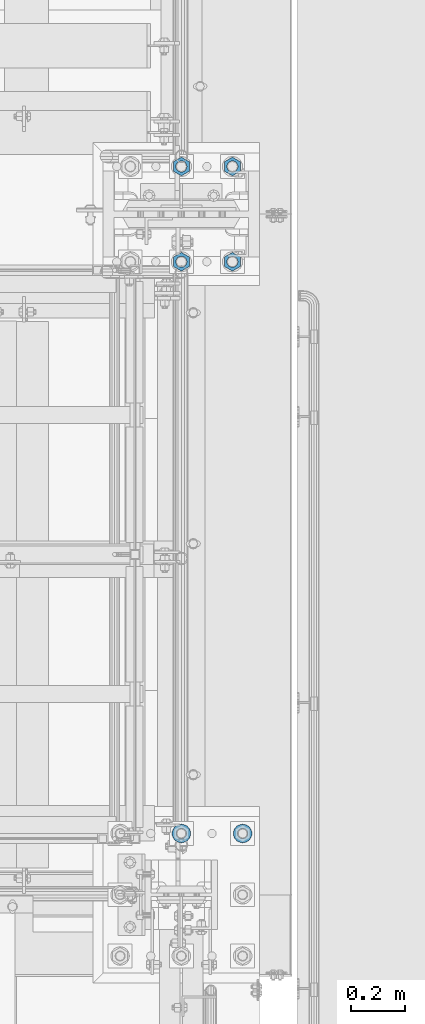
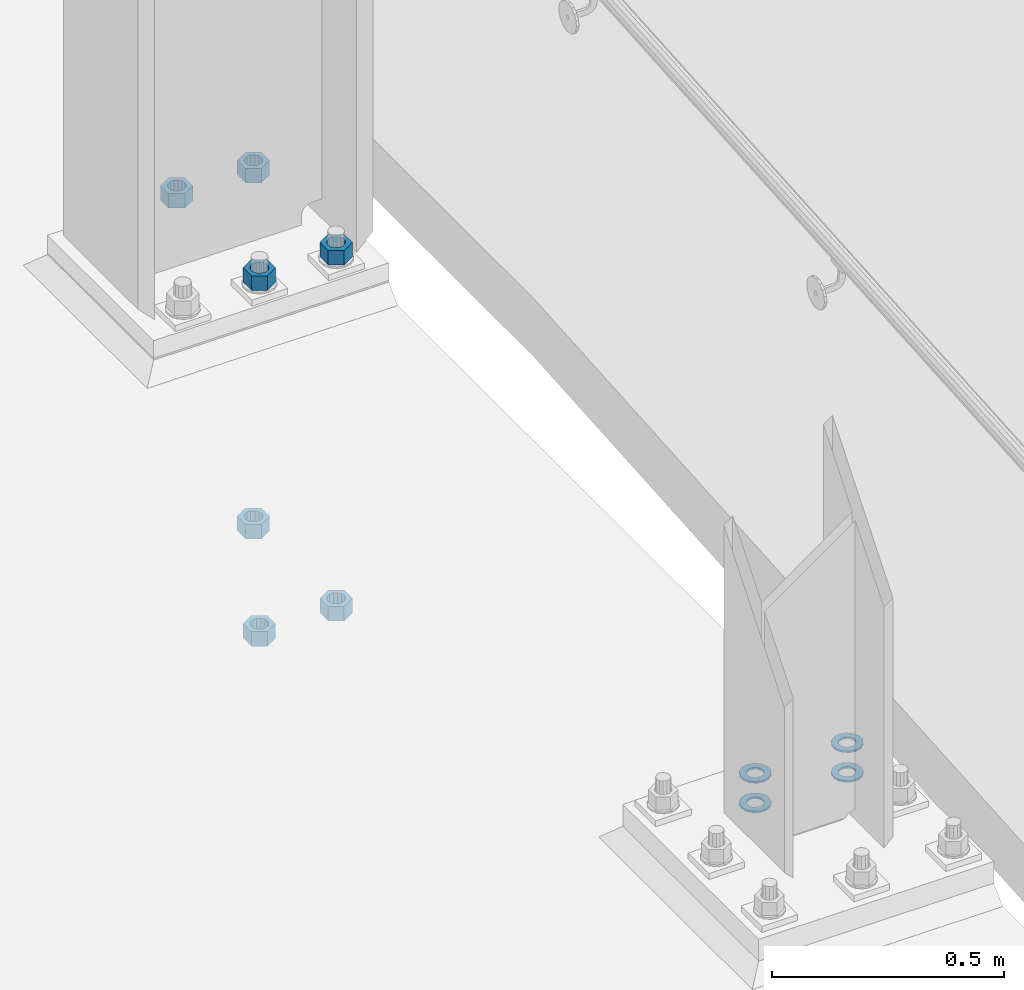
# One storey, part 902 of 1876: 11 columns, 2 elements without a shape of their own.
"""IFC2X3 building model written with IfcOpenShell, lengths in millimetres."""

from ifc_helpers import new_model, si_unit, frame, origin_with_axes, place, context, subcontext, project, spatial, faceted_brep, material, type_object, element, aggregate, save


model = new_model("IFC2X3")

# Units and contexts
model_context = context("Model", 3, precision=1e-05, world=origin_with_axes())
body_context = subcontext(model_context, "Body", "Model", "MODEL_VIEW")
ifc_project = project(units=[si_unit("LENGTHUNIT", "METRE", prefix="MILLI"), si_unit("AREAUNIT", "SQUARE_METRE"), si_unit("VOLUMEUNIT", "CUBIC_METRE"), si_unit("MASSUNIT", "GRAM", prefix="KILO"), si_unit("TIMEUNIT", "SECOND"), si_unit("PLANEANGLEUNIT", "RADIAN"), si_unit("SOLIDANGLEUNIT", "STERADIAN"), si_unit("THERMODYNAMICTEMPERATUREUNIT", "DEGREE_CELSIUS"), si_unit("LUMINOUSINTENSITYUNIT", "LUMEN")], contexts=[model_context])

# Site, building, storey
site_placement = place(None, origin_with_axes())
site = spatial("IfcSite", under=ifc_project, at=site_placement, CompositionType="ELEMENT")
building_placement = place(site_placement, origin_with_axes())
building = spatial("IfcBuilding", under=site, at=building_placement, Name="Undefined", CompositionType="ELEMENT")
storey_placement = place(building_placement, origin_with_axes())
storey = spatial("IfcBuildingStorey", under=building, at=storey_placement, Name="Undefined", CompositionType="ELEMENT", Elevation=0.0)

# Assembly, columns
assembly_1_placement = place(storey_placement, origin_with_axes())
assembly_1 = element("IfcElementAssembly", 1, at=assembly_1_placement, inside=storey, Name="TEMPLATE", AssemblyPlace="NOTDEFINED", PredefinedType="RIGID_FRAME")
ifc_material_1 = material(Name="STEEL/F436")
column_type_1 = type_object("IfcColumnType", Name="1-3/8_WASHER", PredefinedType="NOTDEFINED")
column_1_placement = place(assembly_1_placement, frame((7848.6, -6883.4, 38.1), z_axis=(0.0, -1.0, 0.0), x_axis=(0.0, 0.0, -1.0)))
column_1 = element("IfcColumn", 2, at=column_1_placement, type_object=column_type_1, material=ifc_material_1, Name="WASHER", ObjectType="1-3/8_WASHER", context=body_context, shape_type="Brep", body=[
    faceted_brep([(0.0, -34.9199981689453, 0.0), (0.0, -31.4618312174289, -15.1512193755207), (4.7625, -31.4618312174289, -15.1512193755207), (4.7625, -34.9199981689453, 0.0), (0.0, -21.7722627392632, -27.3015539362077), (4.7625, -21.7722627392632, -27.3015539362077), (0.0, -7.77043060630604, -34.0444809082428), (4.7625, -7.77043060630604, -34.0444809082428), (0.0, 7.77043060630695, -34.0444809082428), (4.7625, 7.77043060630695, -34.0444809082428), (0.0, 21.7722627392632, -27.3015539362077), (4.7625, 21.7722627392632, -27.3015539362077), (0.0, 31.4618312174298, -15.1512193755207), (4.7625, 31.4618312174298, -15.1512193755207), (0.0, 34.9199981689453, 0.0), (4.7625, 34.9199981689453, 0.0), (0.0, 31.4618312174289, 15.1512193755207), (4.7625, 31.4618312174289, 15.1512193755207), (0.0, 21.7722627392632, 27.3015539362077), (4.7625, 21.7722627392632, 27.3015539362077), (0.0, 7.77043060630604, 34.0444809082428), (4.7625, 7.77043060630604, 34.0444809082428), (0.0, -7.77043060630695, 34.0444809082428), (4.7625, -7.77043060630695, 34.0444809082428), (0.0, -21.7722627392632, 27.3015539362077), (4.7625, -21.7722627392632, 27.3015539362077), (0.0, -31.4618312174298, 15.1512193755207), (4.7625, -31.4618312174298, 15.1512193755207), (0.0, 0.0, 19.0499999999993), (0.0, 8.2654848991624, 17.1634562461559), (4.7625, 8.2654848991624, 17.1634562461559), (4.7625, 0.0, 19.0499992370605), (0.0, 14.8938891445259, 11.8774802497237), (4.7625, 14.8938891445259, 11.8774802497237), (0.0, 18.5723759832526, 4.2390236220981), (4.7625, 18.5723759832526, 4.2390236220981), (0.0, 18.5723759832526, -4.2390236220981), (4.7625, 18.5723759832526, -4.2390236220981), (0.0, 14.8938891445259, -11.8774802497237), (4.7625, 14.8938891445259, -11.8774802497237), (0.0, 8.2654848991624, -17.1634562461568), (4.7625, 8.2654848991624, -17.1634562461568), (0.0, 0.0, -19.05), (4.7625, 0.0, -19.0499992370605), (0.0, -8.2654848991624, -17.1634562461559), (4.7625, -8.2654848991624, -17.1634562461559), (0.0, -14.8938891445259, -11.8774802497237), (4.7625, -14.8938891445259, -11.8774802497237), (0.0, -18.5723759832526, -4.2390236220981), (4.7625, -18.5723759832526, -4.2390236220981), (0.0, -18.5723759832526, 4.2390236220981), (4.7625, -18.5723759832526, 4.2390236220981), (0.0, -14.8938891445259, 11.8774802497237), (4.7625, -14.8938891445259, 11.8774802497237), (0.0, -8.2654848991624, 17.1634562461568), (4.7625, -8.2654848991624, 17.1634562461568)], [[[0, 1, 2, 3]], [[1, 4, 5, 2]], [[4, 6, 7, 5]], [[6, 8, 9, 7]], [[8, 10, 11, 9]], [[10, 12, 13, 11]], [[12, 14, 15, 13]], [[14, 16, 17, 15]], [[16, 18, 19, 17]], [[18, 20, 21, 19]], [[20, 22, 23, 21]], [[22, 24, 25, 23]], [[24, 26, 27, 25]], [[26, 0, 3, 27]], [[28, 29, 30, 31]], [[29, 32, 33, 30]], [[32, 34, 35, 33]], [[34, 36, 37, 35]], [[36, 38, 39, 37]], [[38, 40, 41, 39]], [[40, 42, 43, 41]], [[42, 44, 45, 43]], [[44, 46, 47, 45]], [[46, 48, 49, 47]], [[48, 50, 51, 49]], [[50, 52, 53, 51]], [[52, 54, 55, 53]], [[54, 28, 31, 55]], [[5, 7, 9, 11, 13, 15, 17, 19, 21, 23, 25, 27, 3, 2], [33, 35, 37, 39, 41, 43, 45, 47, 49, 51, 53, 55, 31, 30]], [[26, 24, 22, 20, 18, 16, 14, 12, 10, 8, 6, 4, 1, 0], [54, 52, 50, 48, 46, 44, 42, 40, 38, 36, 34, 32, 29, 28]]]),
])
column_2_placement = place(assembly_1_placement, frame((7620.0, -6883.4, 38.1), z_axis=(0.0, -1.0, 0.0), x_axis=(0.0, 0.0, -1.0)))
column_2 = element("IfcColumn", 3, at=column_2_placement, type_object=column_type_1, material=ifc_material_1, Name="WASHER", ObjectType="1-3/8_WASHER", context=body_context, shape_type="Brep", body=[
    faceted_brep([(0.0, -34.9199981689453, 0.0), (0.0, -31.4618312174289, -15.1512193755207), (4.7625, -31.4618312174289, -15.1512193755207), (4.7625, -34.9199981689453, 0.0), (0.0, -21.7722627392632, -27.3015539362077), (4.7625, -21.7722627392632, -27.3015539362077), (0.0, -7.77043060630604, -34.0444809082428), (4.7625, -7.77043060630604, -34.0444809082428), (0.0, 7.77043060630695, -34.0444809082428), (4.7625, 7.77043060630695, -34.0444809082428), (0.0, 21.7722627392632, -27.3015539362077), (4.7625, 21.7722627392632, -27.3015539362077), (0.0, 31.4618312174298, -15.1512193755207), (4.7625, 31.4618312174298, -15.1512193755207), (0.0, 34.9199981689453, 0.0), (4.7625, 34.9199981689453, 0.0), (0.0, 31.4618312174289, 15.1512193755207), (4.7625, 31.4618312174289, 15.1512193755207), (0.0, 21.7722627392632, 27.3015539362077), (4.7625, 21.7722627392632, 27.3015539362077), (0.0, 7.77043060630604, 34.0444809082428), (4.7625, 7.77043060630604, 34.0444809082428), (0.0, -7.77043060630695, 34.0444809082428), (4.7625, -7.77043060630695, 34.0444809082428), (0.0, -21.7722627392632, 27.3015539362077), (4.7625, -21.7722627392632, 27.3015539362077), (0.0, -31.4618312174298, 15.1512193755207), (4.7625, -31.4618312174298, 15.1512193755207), (0.0, 0.0, 19.0499999999993), (0.0, 8.2654848991624, 17.1634562461559), (4.7625, 8.2654848991624, 17.1634562461559), (4.7625, 0.0, 19.0499992370605), (0.0, 14.8938891445259, 11.8774802497237), (4.7625, 14.8938891445259, 11.8774802497237), (0.0, 18.5723759832526, 4.2390236220981), (4.7625, 18.5723759832526, 4.2390236220981), (0.0, 18.5723759832526, -4.2390236220981), (4.7625, 18.5723759832526, -4.2390236220981), (0.0, 14.8938891445259, -11.8774802497237), (4.7625, 14.8938891445259, -11.8774802497237), (0.0, 8.2654848991624, -17.1634562461568), (4.7625, 8.2654848991624, -17.1634562461568), (0.0, 0.0, -19.05), (4.7625, 0.0, -19.0499992370605), (0.0, -8.2654848991624, -17.1634562461559), (4.7625, -8.2654848991624, -17.1634562461559), (0.0, -14.8938891445259, -11.8774802497237), (4.7625, -14.8938891445259, -11.8774802497237), (0.0, -18.5723759832526, -4.2390236220981), (4.7625, -18.5723759832526, -4.2390236220981), (0.0, -18.5723759832526, 4.2390236220981), (4.7625, -18.5723759832526, 4.2390236220981), (0.0, -14.8938891445259, 11.8774802497237), (4.7625, -14.8938891445259, 11.8774802497237), (0.0, -8.2654848991624, 17.1634562461568), (4.7625, -8.2654848991624, 17.1634562461568)], [[[0, 1, 2, 3]], [[1, 4, 5, 2]], [[4, 6, 7, 5]], [[6, 8, 9, 7]], [[8, 10, 11, 9]], [[10, 12, 13, 11]], [[12, 14, 15, 13]], [[14, 16, 17, 15]], [[16, 18, 19, 17]], [[18, 20, 21, 19]], [[20, 22, 23, 21]], [[22, 24, 25, 23]], [[24, 26, 27, 25]], [[26, 0, 3, 27]], [[28, 29, 30, 31]], [[29, 32, 33, 30]], [[32, 34, 35, 33]], [[34, 36, 37, 35]], [[36, 38, 39, 37]], [[38, 40, 41, 39]], [[40, 42, 43, 41]], [[42, 44, 45, 43]], [[44, 46, 47, 45]], [[46, 48, 49, 47]], [[48, 50, 51, 49]], [[50, 52, 53, 51]], [[52, 54, 55, 53]], [[54, 28, 31, 55]], [[5, 7, 9, 11, 13, 15, 17, 19, 21, 23, 25, 27, 3, 2], [33, 35, 37, 39, 41, 43, 45, 47, 49, 51, 53, 55, 31, 30]], [[26, 24, 22, 20, 18, 16, 14, 12, 10, 8, 6, 4, 1, 0], [54, 52, 50, 48, 46, 44, 42, 40, 38, 36, 34, 32, 29, 28]]]),
])
column_3_placement = place(assembly_1_placement, frame((7848.6, -6883.4, 115.8875), z_axis=(-1.0, 0.0, 0.0), x_axis=(0.0, 0.0, -1.0)))
column_3 = element("IfcColumn", 4, at=column_3_placement, type_object=column_type_1, material=ifc_material_1, Name="WASHER", ObjectType="1-3/8_WASHER", context=body_context, shape_type="Brep", body=[
    faceted_brep([(0.0, -34.9199981689453, 0.0), (0.0, -31.4618312174289, -15.1512193755207), (4.7625, -31.4618312174289, -15.1512193755207), (4.7625, -34.9199981689453, 0.0), (0.0, -21.7722627392632, -27.3015539362077), (4.7625, -21.7722627392632, -27.3015539362077), (0.0, -7.77043060630604, -34.0444809082428), (4.7625, -7.77043060630604, -34.0444809082428), (0.0, 7.77043060630695, -34.0444809082428), (4.7625, 7.77043060630695, -34.0444809082428), (0.0, 21.7722627392632, -27.3015539362077), (4.7625, 21.7722627392632, -27.3015539362077), (0.0, 31.4618312174298, -15.1512193755207), (4.7625, 31.4618312174298, -15.1512193755207), (0.0, 34.9199981689453, 0.0), (4.7625, 34.9199981689453, 0.0), (0.0, 31.4618312174289, 15.1512193755207), (4.7625, 31.4618312174289, 15.1512193755207), (0.0, 21.7722627392632, 27.3015539362077), (4.7625, 21.7722627392632, 27.3015539362077), (0.0, 7.77043060630604, 34.0444809082428), (4.7625, 7.77043060630604, 34.0444809082428), (0.0, -7.77043060630695, 34.0444809082428), (4.7625, -7.77043060630695, 34.0444809082428), (0.0, -21.7722627392632, 27.3015539362077), (4.7625, -21.7722627392632, 27.3015539362077), (0.0, -31.4618312174298, 15.1512193755207), (4.7625, -31.4618312174298, 15.1512193755207), (0.0, 0.0, 19.0499999999993), (0.0, 8.2654848991624, 17.1634562461559), (4.7625, 8.2654848991624, 17.1634562461559), (4.7625, 0.0, 19.0499992370605), (0.0, 14.8938891445259, 11.8774802497237), (4.7625, 14.8938891445259, 11.8774802497237), (0.0, 18.5723759832526, 4.2390236220981), (4.7625, 18.5723759832526, 4.2390236220981), (0.0, 18.5723759832526, -4.2390236220981), (4.7625, 18.5723759832526, -4.2390236220981), (0.0, 14.8938891445259, -11.8774802497237), (4.7625, 14.8938891445259, -11.8774802497237), (0.0, 8.2654848991624, -17.1634562461568), (4.7625, 8.2654848991624, -17.1634562461568), (0.0, 0.0, -19.05), (4.7625, 0.0, -19.0499992370605), (0.0, -8.2654848991624, -17.1634562461559), (4.7625, -8.2654848991624, -17.1634562461559), (0.0, -14.8938891445259, -11.8774802497237), (4.7625, -14.8938891445259, -11.8774802497237), (0.0, -18.5723759832526, -4.2390236220981), (4.7625, -18.5723759832526, -4.2390236220981), (0.0, -18.5723759832526, 4.2390236220981), (4.7625, -18.5723759832526, 4.2390236220981), (0.0, -14.8938891445259, 11.8774802497237), (4.7625, -14.8938891445259, 11.8774802497237), (0.0, -8.2654848991624, 17.1634562461568), (4.7625, -8.2654848991624, 17.1634562461568)], [[[0, 1, 2, 3]], [[1, 4, 5, 2]], [[4, 6, 7, 5]], [[6, 8, 9, 7]], [[8, 10, 11, 9]], [[10, 12, 13, 11]], [[12, 14, 15, 13]], [[14, 16, 17, 15]], [[16, 18, 19, 17]], [[18, 20, 21, 19]], [[20, 22, 23, 21]], [[22, 24, 25, 23]], [[24, 26, 27, 25]], [[26, 0, 3, 27]], [[28, 29, 30, 31]], [[29, 32, 33, 30]], [[32, 34, 35, 33]], [[34, 36, 37, 35]], [[36, 38, 39, 37]], [[38, 40, 41, 39]], [[40, 42, 43, 41]], [[42, 44, 45, 43]], [[44, 46, 47, 45]], [[46, 48, 49, 47]], [[48, 50, 51, 49]], [[50, 52, 53, 51]], [[52, 54, 55, 53]], [[54, 28, 31, 55]], [[5, 7, 9, 11, 13, 15, 17, 19, 21, 23, 25, 27, 3, 2], [33, 35, 37, 39, 41, 43, 45, 47, 49, 51, 53, 55, 31, 30]], [[26, 24, 22, 20, 18, 16, 14, 12, 10, 8, 6, 4, 1, 0], [54, 52, 50, 48, 46, 44, 42, 40, 38, 36, 34, 32, 29, 28]]]),
])
column_4_placement = place(assembly_1_placement, frame((7620.0, -6883.4, 115.8875), z_axis=(-1.0, 0.0, 0.0), x_axis=(0.0, 0.0, -1.0)))
column_4 = element("IfcColumn", 5, at=column_4_placement, type_object=column_type_1, material=ifc_material_1, Name="WASHER", ObjectType="1-3/8_WASHER", context=body_context, shape_type="Brep", body=[
    faceted_brep([(0.0, -34.9199981689453, 0.0), (0.0, -31.4618312174289, -15.1512193755207), (4.7625, -31.4618312174289, -15.1512193755207), (4.7625, -34.9199981689453, 0.0), (0.0, -21.7722627392632, -27.3015539362077), (4.7625, -21.7722627392632, -27.3015539362077), (0.0, -7.77043060630604, -34.0444809082428), (4.7625, -7.77043060630604, -34.0444809082428), (0.0, 7.77043060630695, -34.0444809082428), (4.7625, 7.77043060630695, -34.0444809082428), (0.0, 21.7722627392632, -27.3015539362077), (4.7625, 21.7722627392632, -27.3015539362077), (0.0, 31.4618312174298, -15.1512193755207), (4.7625, 31.4618312174298, -15.1512193755207), (0.0, 34.9199981689453, 0.0), (4.7625, 34.9199981689453, 0.0), (0.0, 31.4618312174289, 15.1512193755207), (4.7625, 31.4618312174289, 15.1512193755207), (0.0, 21.7722627392632, 27.3015539362077), (4.7625, 21.7722627392632, 27.3015539362077), (0.0, 7.77043060630604, 34.0444809082428), (4.7625, 7.77043060630604, 34.0444809082428), (0.0, -7.77043060630695, 34.0444809082428), (4.7625, -7.77043060630695, 34.0444809082428), (0.0, -21.7722627392632, 27.3015539362077), (4.7625, -21.7722627392632, 27.3015539362077), (0.0, -31.4618312174298, 15.1512193755207), (4.7625, -31.4618312174298, 15.1512193755207), (0.0, 0.0, 19.0499999999993), (0.0, 8.2654848991624, 17.1634562461559), (4.7625, 8.2654848991624, 17.1634562461559), (4.7625, 0.0, 19.0499992370605), (0.0, 14.8938891445259, 11.8774802497237), (4.7625, 14.8938891445259, 11.8774802497237), (0.0, 18.5723759832526, 4.2390236220981), (4.7625, 18.5723759832526, 4.2390236220981), (0.0, 18.5723759832526, -4.2390236220981), (4.7625, 18.5723759832526, -4.2390236220981), (0.0, 14.8938891445259, -11.8774802497237), (4.7625, 14.8938891445259, -11.8774802497237), (0.0, 8.2654848991624, -17.1634562461568), (4.7625, 8.2654848991624, -17.1634562461568), (0.0, 0.0, -19.05), (4.7625, 0.0, -19.0499992370605), (0.0, -8.2654848991624, -17.1634562461559), (4.7625, -8.2654848991624, -17.1634562461559), (0.0, -14.8938891445259, -11.8774802497237), (4.7625, -14.8938891445259, -11.8774802497237), (0.0, -18.5723759832526, -4.2390236220981), (4.7625, -18.5723759832526, -4.2390236220981), (0.0, -18.5723759832526, 4.2390236220981), (4.7625, -18.5723759832526, 4.2390236220981), (0.0, -14.8938891445259, 11.8774802497237), (4.7625, -14.8938891445259, 11.8774802497237), (0.0, -8.2654848991624, 17.1634562461568), (4.7625, -8.2654848991624, 17.1634562461568)], [[[0, 1, 2, 3]], [[1, 4, 5, 2]], [[4, 6, 7, 5]], [[6, 8, 9, 7]], [[8, 10, 11, 9]], [[10, 12, 13, 11]], [[12, 14, 15, 13]], [[14, 16, 17, 15]], [[16, 18, 19, 17]], [[18, 20, 21, 19]], [[20, 22, 23, 21]], [[22, 24, 25, 23]], [[24, 26, 27, 25]], [[26, 0, 3, 27]], [[28, 29, 30, 31]], [[29, 32, 33, 30]], [[32, 34, 35, 33]], [[34, 36, 37, 35]], [[36, 38, 39, 37]], [[38, 40, 41, 39]], [[40, 42, 43, 41]], [[42, 44, 45, 43]], [[44, 46, 47, 45]], [[46, 48, 49, 47]], [[48, 50, 51, 49]], [[50, 52, 53, 51]], [[52, 54, 55, 53]], [[54, 28, 31, 55]], [[5, 7, 9, 11, 13, 15, 17, 19, 21, 23, 25, 27, 3, 2], [33, 35, 37, 39, 41, 43, 45, 47, 49, 51, 53, 55, 31, 30]], [[26, 24, 22, 20, 18, 16, 14, 12, 10, 8, 6, 4, 1, 0], [54, 52, 50, 48, 46, 44, 42, 40, 38, 36, 34, 32, 29, 28]]]),
])
aggregate(assembly_1, [column_1, column_2, column_3, column_4])

assembly_2_placement = place(storey_placement, origin_with_axes())
assembly_2 = element("IfcElementAssembly", 6, at=assembly_2_placement, inside=storey, Name="TEMPLATE", AssemblyPlace="NOTDEFINED", PredefinedType="RIGID_FRAME")
ifc_material_2 = material(Name="STEEL/A563")
column_type_2 = type_object("IfcColumnType", Name="1-1/2_HEAVY_HEX_NUT", PredefinedType="NOTDEFINED")
column_5_placement = place(assembly_2_placement, frame((7810.5, -4749.8, 147.6375), z_axis=(1.0, 0.0, 0.0), x_axis=(0.0, 0.0, -1.0)))
column_5 = element("IfcColumn", 7, at=column_5_placement, type_object=column_type_2, material=ifc_material_2, Name="NUT", ObjectType="1-1/2_HEAVY_HEX_NUT", context=body_context, shape_type="Brep", body=[
    faceted_brep([(0.0, -34.9199981689453, 0.0), (0.0, -17.4599990844727, -30.25), (38.1, -17.4599990844727, -30.25), (38.1, -34.9199981689453, 0.0), (0.0, 17.4599990844727, -30.25), (38.1, 17.4599990844727, -30.25), (0.0, 34.9199981689453, 0.0), (38.1, 34.9199981689453, 0.0), (0.0, 17.4599990844727, 30.25), (38.1, 17.4599990844727, 30.25), (0.0, -17.4599990844727, 30.25), (38.1, -17.4599990844727, 30.25), (0.0, 0.0, 20.6399993896484), (0.0, 8.95536011056538, 18.5959968835978), (38.1, 8.95536011056447, 18.595996883598), (38.1, 0.0, 20.6399993896484), (0.0, 16.1370013209489, 12.8688291298158), (38.1, 16.137001320948, 12.8688291298162), (0.0, 20.1225115123834, 4.59283194104228), (38.1, 20.1225115123843, 4.59283194104222), (0.0, 20.1225115123834, -4.59283194104228), (38.1, 20.1225115123843, -4.59283194104239), (0.0, 16.1370013209489, -12.8688291298167), (38.1, 16.137001320948, -12.8688291298163), (0.0, 8.95536011056538, -18.5959968835978), (38.1, 8.95536011056447, -18.5959968835982), (0.0, 0.0, -20.6399993896484), (38.1, 0.0, -20.6399993896484), (0.0, -8.95536011056538, -18.5959968835978), (38.1, -8.95536011056447, -18.595996883598), (0.0, -16.1370013209489, -12.8688291298158), (38.1, -16.137001320948, -12.8688291298162), (0.0, -20.1225115123834, -4.59283194104228), (38.1, -20.1225115123843, -4.59283194104222), (0.0, -20.1225115123834, 4.59283194104228), (38.1, -20.1225115123843, 4.59283194104239), (0.0, -16.1370013209489, 12.8688291298167), (38.1, -16.137001320948, 12.8688291298163), (0.0, -8.95536011056538, 18.5959968835978), (38.1, -8.95536011056447, 18.5959968835982)], [[[0, 1, 2, 3]], [[1, 4, 5, 2]], [[4, 6, 7, 5]], [[6, 8, 9, 7]], [[8, 10, 11, 9]], [[10, 0, 3, 11]], [[12, 13, 14, 15]], [[13, 16, 17, 14]], [[16, 18, 19, 17]], [[18, 20, 21, 19]], [[20, 22, 23, 21]], [[22, 24, 25, 23]], [[24, 26, 27, 25]], [[26, 28, 29, 27]], [[28, 30, 31, 29]], [[30, 32, 33, 31]], [[32, 34, 35, 33]], [[34, 36, 37, 35]], [[36, 38, 39, 37]], [[38, 12, 15, 39]], [[5, 7, 9, 11, 3, 2], [17, 19, 21, 23, 25, 27, 29, 31, 33, 35, 37, 39, 15, 14]], [[10, 8, 6, 4, 1, 0], [38, 36, 34, 32, 30, 28, 26, 24, 22, 20, 18, 16, 13, 12]]]),
])
column_6_placement = place(assembly_2_placement, frame((7810.5, -4749.8, -787.4), z_axis=(1.0, 0.0, 0.0), x_axis=(0.0, 0.0, -1.0)))
column_6 = element("IfcColumn", 8, at=column_6_placement, type_object=column_type_2, material=ifc_material_2, Name="NUT", ObjectType="1-1/2_HEAVY_HEX_NUT", context=body_context, shape_type="Brep", body=[
    faceted_brep([(0.0, -34.9199981689453, 0.0), (0.0, -17.4599990844727, -30.25), (38.1, -17.4599990844727, -30.25), (38.1, -34.9199981689453, 0.0), (0.0, 17.4599990844727, -30.25), (38.1, 17.4599990844727, -30.25), (0.0, 34.9199981689453, 0.0), (38.1, 34.9199981689453, 0.0), (0.0, 17.4599990844727, 30.25), (38.1, 17.4599990844727, 30.25), (0.0, -17.4599990844727, 30.25), (38.1, -17.4599990844727, 30.25), (0.0, 0.0, 20.6399993896484), (0.0, 8.95536011056538, 18.5959968835978), (38.1, 8.95536011056447, 18.595996883598), (38.1, 0.0, 20.6399993896484), (0.0, 16.1370013209489, 12.8688291298158), (38.1, 16.137001320948, 12.8688291298162), (0.0, 20.1225115123834, 4.59283194104228), (38.1, 20.1225115123843, 4.59283194104222), (0.0, 20.1225115123834, -4.59283194104228), (38.1, 20.1225115123843, -4.59283194104239), (0.0, 16.1370013209489, -12.8688291298167), (38.1, 16.137001320948, -12.8688291298163), (0.0, 8.95536011056538, -18.5959968835978), (38.1, 8.95536011056447, -18.5959968835982), (0.0, 0.0, -20.6399993896484), (38.1, 0.0, -20.6399993896484), (0.0, -8.95536011056538, -18.5959968835978), (38.1, -8.95536011056447, -18.595996883598), (0.0, -16.1370013209489, -12.8688291298158), (38.1, -16.137001320948, -12.8688291298162), (0.0, -20.1225115123834, -4.59283194104228), (38.1, -20.1225115123843, -4.59283194104222), (0.0, -20.1225115123834, 4.59283194104228), (38.1, -20.1225115123843, 4.59283194104239), (0.0, -16.1370013209489, 12.8688291298167), (38.1, -16.137001320948, 12.8688291298163), (0.0, -8.95536011056538, 18.5959968835978), (38.1, -8.95536011056447, 18.5959968835982)], [[[0, 1, 2, 3]], [[1, 4, 5, 2]], [[4, 6, 7, 5]], [[6, 8, 9, 7]], [[8, 10, 11, 9]], [[10, 0, 3, 11]], [[12, 13, 14, 15]], [[13, 16, 17, 14]], [[16, 18, 19, 17]], [[18, 20, 21, 19]], [[20, 22, 23, 21]], [[22, 24, 25, 23]], [[24, 26, 27, 25]], [[26, 28, 29, 27]], [[28, 30, 31, 29]], [[30, 32, 33, 31]], [[32, 34, 35, 33]], [[34, 36, 37, 35]], [[36, 38, 39, 37]], [[38, 12, 15, 39]], [[5, 7, 9, 11, 3, 2], [17, 19, 21, 23, 25, 27, 29, 31, 33, 35, 37, 39, 15, 14]], [[10, 8, 6, 4, 1, 0], [38, 36, 34, 32, 30, 28, 26, 24, 22, 20, 18, 16, 13, 12]]]),
])
column_7_placement = place(assembly_2_placement, frame((7810.5, -4394.2, 147.6375), z_axis=(-1.0, 0.0, 0.0), x_axis=(0.0, 0.0, -1.0)))
column_7 = element("IfcColumn", 9, at=column_7_placement, type_object=column_type_2, material=ifc_material_2, Name="NUT", ObjectType="1-1/2_HEAVY_HEX_NUT", context=body_context, shape_type="Brep", body=[
    faceted_brep([(0.0, -34.9199981689453, 0.0), (0.0, -17.4599990844727, -30.25), (38.1, -17.4599990844727, -30.25), (38.1, -34.9199981689453, 0.0), (0.0, 17.4599990844727, -30.25), (38.1, 17.4599990844727, -30.25), (0.0, 34.9199981689453, 0.0), (38.1, 34.9199981689453, 0.0), (0.0, 17.4599990844727, 30.25), (38.1, 17.4599990844727, 30.25), (0.0, -17.4599990844727, 30.25), (38.1, -17.4599990844727, 30.25), (0.0, 0.0, 20.6399993896484), (0.0, 8.95536011056538, 18.5959968835978), (38.1, 8.95536011056447, 18.595996883598), (38.1, 0.0, 20.6399993896484), (0.0, 16.1370013209489, 12.8688291298158), (38.1, 16.137001320948, 12.8688291298162), (0.0, 20.1225115123834, 4.59283194104228), (38.1, 20.1225115123843, 4.59283194104222), (0.0, 20.1225115123834, -4.59283194104228), (38.1, 20.1225115123843, -4.59283194104239), (0.0, 16.1370013209489, -12.8688291298167), (38.1, 16.137001320948, -12.8688291298163), (0.0, 8.95536011056538, -18.5959968835978), (38.1, 8.95536011056447, -18.5959968835982), (0.0, 0.0, -20.6399993896484), (38.1, 0.0, -20.6399993896484), (0.0, -8.95536011056538, -18.5959968835978), (38.1, -8.95536011056447, -18.595996883598), (0.0, -16.1370013209489, -12.8688291298158), (38.1, -16.137001320948, -12.8688291298162), (0.0, -20.1225115123834, -4.59283194104228), (38.1, -20.1225115123843, -4.59283194104222), (0.0, -20.1225115123834, 4.59283194104228), (38.1, -20.1225115123843, 4.59283194104239), (0.0, -16.1370013209489, 12.8688291298167), (38.1, -16.137001320948, 12.8688291298163), (0.0, -8.95536011056538, 18.5959968835978), (38.1, -8.95536011056447, 18.5959968835982)], [[[0, 1, 2, 3]], [[1, 4, 5, 2]], [[4, 6, 7, 5]], [[6, 8, 9, 7]], [[8, 10, 11, 9]], [[10, 0, 3, 11]], [[12, 13, 14, 15]], [[13, 16, 17, 14]], [[16, 18, 19, 17]], [[18, 20, 21, 19]], [[20, 22, 23, 21]], [[22, 24, 25, 23]], [[24, 26, 27, 25]], [[26, 28, 29, 27]], [[28, 30, 31, 29]], [[30, 32, 33, 31]], [[32, 34, 35, 33]], [[34, 36, 37, 35]], [[36, 38, 39, 37]], [[38, 12, 15, 39]], [[5, 7, 9, 11, 3, 2], [17, 19, 21, 23, 25, 27, 29, 31, 33, 35, 37, 39, 15, 14]], [[10, 8, 6, 4, 1, 0], [38, 36, 34, 32, 30, 28, 26, 24, 22, 20, 18, 16, 13, 12]]]),
])
column_8_placement = place(assembly_2_placement, frame((7810.5, -4394.2, -787.4), z_axis=(-1.0, 0.0, 0.0), x_axis=(0.0, 0.0, -1.0)))
column_8 = element("IfcColumn", 10, at=column_8_placement, type_object=column_type_2, material=ifc_material_2, Name="NUT", ObjectType="1-1/2_HEAVY_HEX_NUT", context=body_context, shape_type="Brep", body=[
    faceted_brep([(0.0, -34.9199981689453, 0.0), (0.0, -17.4599990844727, -30.25), (38.1, -17.4599990844727, -30.25), (38.1, -34.9199981689453, 0.0), (0.0, 17.4599990844727, -30.25), (38.1, 17.4599990844727, -30.25), (0.0, 34.9199981689453, 0.0), (38.1, 34.9199981689453, 0.0), (0.0, 17.4599990844727, 30.25), (38.1, 17.4599990844727, 30.25), (0.0, -17.4599990844727, 30.25), (38.1, -17.4599990844727, 30.25), (0.0, 0.0, 20.6399993896484), (0.0, 8.95536011056538, 18.5959968835978), (38.1, 8.95536011056447, 18.595996883598), (38.1, 0.0, 20.6399993896484), (0.0, 16.1370013209489, 12.8688291298158), (38.1, 16.137001320948, 12.8688291298162), (0.0, 20.1225115123834, 4.59283194104228), (38.1, 20.1225115123843, 4.59283194104222), (0.0, 20.1225115123834, -4.59283194104228), (38.1, 20.1225115123843, -4.59283194104239), (0.0, 16.1370013209489, -12.8688291298167), (38.1, 16.137001320948, -12.8688291298163), (0.0, 8.95536011056538, -18.5959968835978), (38.1, 8.95536011056447, -18.5959968835982), (0.0, 0.0, -20.6399993896484), (38.1, 0.0, -20.6399993896484), (0.0, -8.95536011056538, -18.5959968835978), (38.1, -8.95536011056447, -18.595996883598), (0.0, -16.1370013209489, -12.8688291298158), (38.1, -16.137001320948, -12.8688291298162), (0.0, -20.1225115123834, -4.59283194104228), (38.1, -20.1225115123843, -4.59283194104222), (0.0, -20.1225115123834, 4.59283194104228), (38.1, -20.1225115123843, 4.59283194104239), (0.0, -16.1370013209489, 12.8688291298167), (38.1, -16.137001320948, 12.8688291298163), (0.0, -8.95536011056538, 18.5959968835978), (38.1, -8.95536011056447, 18.5959968835982)], [[[0, 1, 2, 3]], [[1, 4, 5, 2]], [[4, 6, 7, 5]], [[6, 8, 9, 7]], [[8, 10, 11, 9]], [[10, 0, 3, 11]], [[12, 13, 14, 15]], [[13, 16, 17, 14]], [[16, 18, 19, 17]], [[18, 20, 21, 19]], [[20, 22, 23, 21]], [[22, 24, 25, 23]], [[24, 26, 27, 25]], [[26, 28, 29, 27]], [[28, 30, 31, 29]], [[30, 32, 33, 31]], [[32, 34, 35, 33]], [[34, 36, 37, 35]], [[36, 38, 39, 37]], [[38, 12, 15, 39]], [[5, 7, 9, 11, 3, 2], [17, 19, 21, 23, 25, 27, 29, 31, 33, 35, 37, 39, 15, 14]], [[10, 8, 6, 4, 1, 0], [38, 36, 34, 32, 30, 28, 26, 24, 22, 20, 18, 16, 13, 12]]]),
])
column_9_placement = place(assembly_2_placement, frame((7620.0, -4749.8, 147.6375), z_axis=(1.0, 0.0, 0.0), x_axis=(0.0, 0.0, -1.0)))
column_9 = element("IfcColumn", 11, at=column_9_placement, type_object=column_type_2, material=ifc_material_2, Name="NUT", ObjectType="1-1/2_HEAVY_HEX_NUT", context=body_context, shape_type="Brep", body=[
    faceted_brep([(0.0, -34.9199981689453, 0.0), (0.0, -17.4599990844727, -30.25), (38.1, -17.4599990844727, -30.25), (38.1, -34.9199981689453, 0.0), (0.0, 17.4599990844727, -30.25), (38.1, 17.4599990844727, -30.25), (0.0, 34.9199981689453, 0.0), (38.1, 34.9199981689453, 0.0), (0.0, 17.4599990844727, 30.25), (38.1, 17.4599990844727, 30.25), (0.0, -17.4599990844727, 30.25), (38.1, -17.4599990844727, 30.25), (0.0, 0.0, 20.6399993896484), (0.0, 8.95536011056538, 18.5959968835978), (38.1, 8.95536011056447, 18.595996883598), (38.1, 0.0, 20.6399993896484), (0.0, 16.1370013209489, 12.8688291298158), (38.1, 16.137001320948, 12.8688291298162), (0.0, 20.1225115123834, 4.59283194104228), (38.1, 20.1225115123843, 4.59283194104222), (0.0, 20.1225115123834, -4.59283194104228), (38.1, 20.1225115123843, -4.59283194104239), (0.0, 16.1370013209489, -12.8688291298167), (38.1, 16.137001320948, -12.8688291298163), (0.0, 8.95536011056538, -18.5959968835978), (38.1, 8.95536011056447, -18.5959968835982), (0.0, 0.0, -20.6399993896484), (38.1, 0.0, -20.6399993896484), (0.0, -8.95536011056538, -18.5959968835978), (38.1, -8.95536011056447, -18.595996883598), (0.0, -16.1370013209489, -12.8688291298158), (38.1, -16.137001320948, -12.8688291298162), (0.0, -20.1225115123834, -4.59283194104228), (38.1, -20.1225115123843, -4.59283194104222), (0.0, -20.1225115123834, 4.59283194104228), (38.1, -20.1225115123843, 4.59283194104239), (0.0, -16.1370013209489, 12.8688291298167), (38.1, -16.137001320948, 12.8688291298163), (0.0, -8.95536011056538, 18.5959968835978), (38.1, -8.95536011056447, 18.5959968835982)], [[[0, 1, 2, 3]], [[1, 4, 5, 2]], [[4, 6, 7, 5]], [[6, 8, 9, 7]], [[8, 10, 11, 9]], [[10, 0, 3, 11]], [[12, 13, 14, 15]], [[13, 16, 17, 14]], [[16, 18, 19, 17]], [[18, 20, 21, 19]], [[20, 22, 23, 21]], [[22, 24, 25, 23]], [[24, 26, 27, 25]], [[26, 28, 29, 27]], [[28, 30, 31, 29]], [[30, 32, 33, 31]], [[32, 34, 35, 33]], [[34, 36, 37, 35]], [[36, 38, 39, 37]], [[38, 12, 15, 39]], [[5, 7, 9, 11, 3, 2], [17, 19, 21, 23, 25, 27, 29, 31, 33, 35, 37, 39, 15, 14]], [[10, 8, 6, 4, 1, 0], [38, 36, 34, 32, 30, 28, 26, 24, 22, 20, 18, 16, 13, 12]]]),
])
column_10_placement = place(assembly_2_placement, frame((7620.0, -4749.8, -787.4), z_axis=(1.0, 0.0, 0.0), x_axis=(0.0, 0.0, -1.0)))
column_10 = element("IfcColumn", 12, at=column_10_placement, type_object=column_type_2, material=ifc_material_2, Name="NUT", ObjectType="1-1/2_HEAVY_HEX_NUT", context=body_context, shape_type="Brep", body=[
    faceted_brep([(0.0, -34.9199981689453, 0.0), (0.0, -17.4599990844727, -30.25), (38.1, -17.4599990844727, -30.25), (38.1, -34.9199981689453, 0.0), (0.0, 17.4599990844727, -30.25), (38.1, 17.4599990844727, -30.25), (0.0, 34.9199981689453, 0.0), (38.1, 34.9199981689453, 0.0), (0.0, 17.4599990844727, 30.25), (38.1, 17.4599990844727, 30.25), (0.0, -17.4599990844727, 30.25), (38.1, -17.4599990844727, 30.25), (0.0, 0.0, 20.6399993896484), (0.0, 8.95536011056538, 18.5959968835978), (38.1, 8.95536011056447, 18.595996883598), (38.1, 0.0, 20.6399993896484), (0.0, 16.1370013209489, 12.8688291298158), (38.1, 16.137001320948, 12.8688291298162), (0.0, 20.1225115123834, 4.59283194104228), (38.1, 20.1225115123843, 4.59283194104222), (0.0, 20.1225115123834, -4.59283194104228), (38.1, 20.1225115123843, -4.59283194104239), (0.0, 16.1370013209489, -12.8688291298167), (38.1, 16.137001320948, -12.8688291298163), (0.0, 8.95536011056538, -18.5959968835978), (38.1, 8.95536011056447, -18.5959968835982), (0.0, 0.0, -20.6399993896484), (38.1, 0.0, -20.6399993896484), (0.0, -8.95536011056538, -18.5959968835978), (38.1, -8.95536011056447, -18.595996883598), (0.0, -16.1370013209489, -12.8688291298158), (38.1, -16.137001320948, -12.8688291298162), (0.0, -20.1225115123834, -4.59283194104228), (38.1, -20.1225115123843, -4.59283194104222), (0.0, -20.1225115123834, 4.59283194104228), (38.1, -20.1225115123843, 4.59283194104239), (0.0, -16.1370013209489, 12.8688291298167), (38.1, -16.137001320948, 12.8688291298163), (0.0, -8.95536011056538, 18.5959968835978), (38.1, -8.95536011056447, 18.5959968835982)], [[[0, 1, 2, 3]], [[1, 4, 5, 2]], [[4, 6, 7, 5]], [[6, 8, 9, 7]], [[8, 10, 11, 9]], [[10, 0, 3, 11]], [[12, 13, 14, 15]], [[13, 16, 17, 14]], [[16, 18, 19, 17]], [[18, 20, 21, 19]], [[20, 22, 23, 21]], [[22, 24, 25, 23]], [[24, 26, 27, 25]], [[26, 28, 29, 27]], [[28, 30, 31, 29]], [[30, 32, 33, 31]], [[32, 34, 35, 33]], [[34, 36, 37, 35]], [[36, 38, 39, 37]], [[38, 12, 15, 39]], [[5, 7, 9, 11, 3, 2], [17, 19, 21, 23, 25, 27, 29, 31, 33, 35, 37, 39, 15, 14]], [[10, 8, 6, 4, 1, 0], [38, 36, 34, 32, 30, 28, 26, 24, 22, 20, 18, 16, 13, 12]]]),
])
column_11_placement = place(assembly_2_placement, frame((7620.0, -4394.2, 147.6375), z_axis=(-1.0, 0.0, 0.0), x_axis=(0.0, 0.0, -1.0)))
column_11 = element("IfcColumn", 13, at=column_11_placement, type_object=column_type_2, material=ifc_material_2, Name="NUT", ObjectType="1-1/2_HEAVY_HEX_NUT", context=body_context, shape_type="Brep", body=[
    faceted_brep([(0.0, -34.9199981689453, 0.0), (0.0, -17.4599990844727, -30.25), (38.1, -17.4599990844727, -30.25), (38.1, -34.9199981689453, 0.0), (0.0, 17.4599990844727, -30.25), (38.1, 17.4599990844727, -30.25), (0.0, 34.9199981689453, 0.0), (38.1, 34.9199981689453, 0.0), (0.0, 17.4599990844727, 30.25), (38.1, 17.4599990844727, 30.25), (0.0, -17.4599990844727, 30.25), (38.1, -17.4599990844727, 30.25), (0.0, 0.0, 20.6399993896484), (0.0, 8.95536011056538, 18.5959968835978), (38.1, 8.95536011056447, 18.595996883598), (38.1, 0.0, 20.6399993896484), (0.0, 16.1370013209489, 12.8688291298158), (38.1, 16.137001320948, 12.8688291298162), (0.0, 20.1225115123834, 4.59283194104228), (38.1, 20.1225115123843, 4.59283194104222), (0.0, 20.1225115123834, -4.59283194104228), (38.1, 20.1225115123843, -4.59283194104239), (0.0, 16.1370013209489, -12.8688291298167), (38.1, 16.137001320948, -12.8688291298163), (0.0, 8.95536011056538, -18.5959968835978), (38.1, 8.95536011056447, -18.5959968835982), (0.0, 0.0, -20.6399993896484), (38.1, 0.0, -20.6399993896484), (0.0, -8.95536011056538, -18.5959968835978), (38.1, -8.95536011056447, -18.595996883598), (0.0, -16.1370013209489, -12.8688291298158), (38.1, -16.137001320948, -12.8688291298162), (0.0, -20.1225115123834, -4.59283194104228), (38.1, -20.1225115123843, -4.59283194104222), (0.0, -20.1225115123834, 4.59283194104228), (38.1, -20.1225115123843, 4.59283194104239), (0.0, -16.1370013209489, 12.8688291298167), (38.1, -16.137001320948, 12.8688291298163), (0.0, -8.95536011056538, 18.5959968835978), (38.1, -8.95536011056447, 18.5959968835982)], [[[0, 1, 2, 3]], [[1, 4, 5, 2]], [[4, 6, 7, 5]], [[6, 8, 9, 7]], [[8, 10, 11, 9]], [[10, 0, 3, 11]], [[12, 13, 14, 15]], [[13, 16, 17, 14]], [[16, 18, 19, 17]], [[18, 20, 21, 19]], [[20, 22, 23, 21]], [[22, 24, 25, 23]], [[24, 26, 27, 25]], [[26, 28, 29, 27]], [[28, 30, 31, 29]], [[30, 32, 33, 31]], [[32, 34, 35, 33]], [[34, 36, 37, 35]], [[36, 38, 39, 37]], [[38, 12, 15, 39]], [[5, 7, 9, 11, 3, 2], [17, 19, 21, 23, 25, 27, 29, 31, 33, 35, 37, 39, 15, 14]], [[10, 8, 6, 4, 1, 0], [38, 36, 34, 32, 30, 28, 26, 24, 22, 20, 18, 16, 13, 12]]]),
])
aggregate(assembly_2, [column_5, column_6, column_7, column_8, column_9, column_10, column_11])

save(model, "model.ifc")
